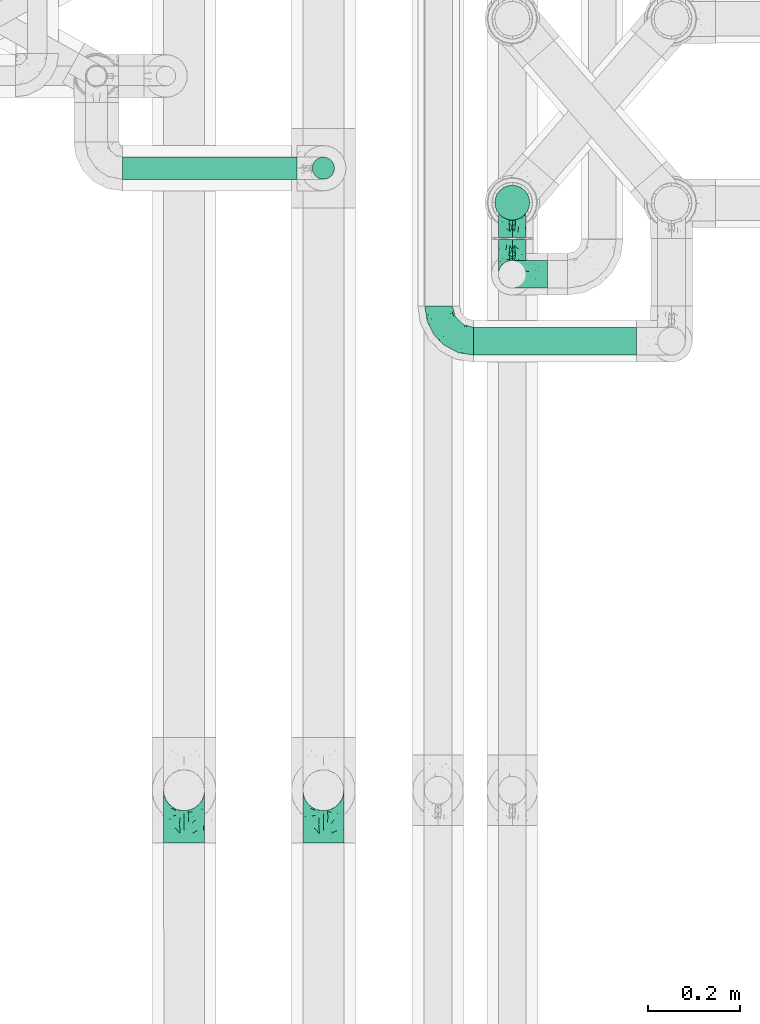
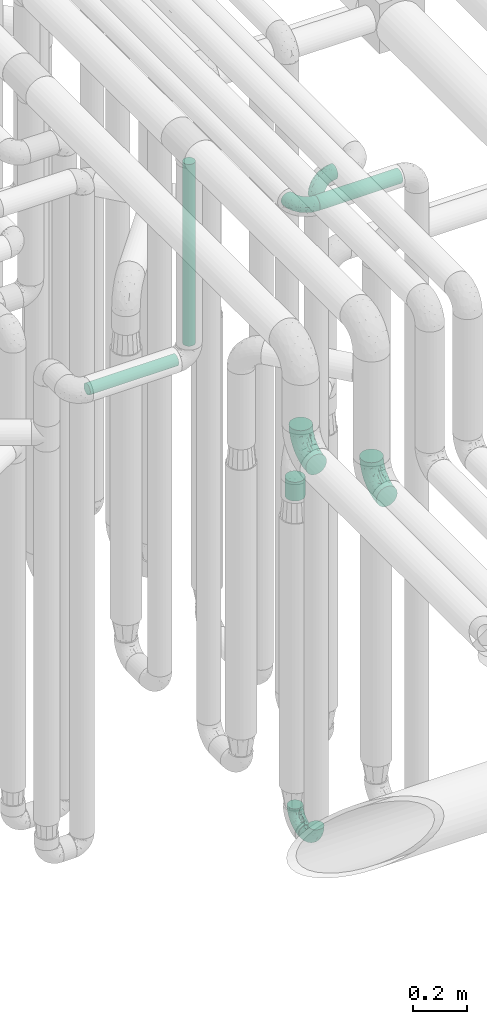
# One storey, part 606 of 827: 6 flow fittings, 4 flow segments.
"""IFC2X3 building model written with IfcOpenShell, lengths in millimetres."""

from ifc_helpers import new_model, entity, si_unit, converted_unit, derived_unit, direction, frame, origin, origin_2d_with_axis, place, context, subcontext, project, spatial, polyline, circle, outline, extrude, faceted_brep, source, transform, mapped, material, type_object, type_shapes, element, save


model = new_model("IFC2X3")

# Units and contexts
model_context = context("Model", 3, precision=0.01, world=origin(), true_north=direction((6.12303176911189e-17, 1.0)))
body_context = subcontext(model_context, "Body", "Model", "MODEL_VIEW")
ifc_project = project(units=[si_unit("LENGTHUNIT", "METRE", prefix="MILLI"), si_unit("AREAUNIT", "SQUARE_METRE"), si_unit("VOLUMEUNIT", "CUBIC_METRE"), converted_unit("PLANEANGLEUNIT", "DEGREE", entity("IfcRatioMeasure", 0.0174532925199433), si_unit("PLANEANGLEUNIT", "RADIAN"), dimensions=[0, 0, 0, 0, 0, 0, 0]), si_unit("MASSUNIT", "GRAM", prefix="KILO"), derived_unit("MASSDENSITYUNIT", [(si_unit("MASSUNIT", "GRAM", prefix="KILO"), 1), (si_unit("LENGTHUNIT", "METRE"), -3)]), derived_unit("MOMENTOFINERTIAUNIT", [(si_unit("LENGTHUNIT", "METRE"), 4)]), si_unit("TIMEUNIT", "SECOND"), si_unit("FREQUENCYUNIT", "HERTZ"), si_unit("THERMODYNAMICTEMPERATUREUNIT", "DEGREE_CELSIUS"), derived_unit("THERMALTRANSMITTANCEUNIT", [(si_unit("MASSUNIT", "GRAM", prefix="KILO"), 1), (si_unit("THERMODYNAMICTEMPERATUREUNIT", "KELVIN"), -1), (si_unit("TIMEUNIT", "SECOND"), -3)]), derived_unit("VOLUMETRICFLOWRATEUNIT", [(si_unit("LENGTHUNIT", "METRE"), 3), (si_unit("TIMEUNIT", "SECOND"), -1)]), derived_unit("MASSFLOWRATEUNIT", [(si_unit("MASSUNIT", "GRAM", prefix="KILO"), 1), (si_unit("TIMEUNIT", "SECOND"), -1)]), derived_unit("ROTATIONALFREQUENCYUNIT", [(si_unit("TIMEUNIT", "SECOND"), -1)]), si_unit("ELECTRICCURRENTUNIT", "AMPERE"), si_unit("ELECTRICVOLTAGEUNIT", "VOLT"), si_unit("POWERUNIT", "WATT"), si_unit("FORCEUNIT", "NEWTON", prefix="KILO"), si_unit("ILLUMINANCEUNIT", "LUX"), si_unit("LUMINOUSFLUXUNIT", "LUMEN"), si_unit("LUMINOUSINTENSITYUNIT", "CANDELA"), derived_unit("USERDEFINED", [(si_unit("MASSUNIT", "GRAM", prefix="KILO"), -1), (si_unit("LENGTHUNIT", "METRE"), -2), (si_unit("TIMEUNIT", "SECOND"), 3), (si_unit("LUMINOUSFLUXUNIT", "LUMEN"), 1)]), derived_unit("LINEARVELOCITYUNIT", [(si_unit("LENGTHUNIT", "METRE"), 1), (si_unit("TIMEUNIT", "SECOND"), -1)]), si_unit("PRESSUREUNIT", "PASCAL"), derived_unit("USERDEFINED", [(si_unit("LENGTHUNIT", "METRE"), -2), (si_unit("MASSUNIT", "GRAM", prefix="KILO"), 1), (si_unit("TIMEUNIT", "SECOND"), -2)]), derived_unit("LINEARFORCEUNIT", [(si_unit("MASSUNIT", "GRAM", prefix="KILO"), 1), (si_unit("LENGTHUNIT", "METRE"), 1), (si_unit("TIMEUNIT", "SECOND"), -2), (si_unit("LENGTHUNIT", "METRE"), -1)]), derived_unit("PLANARFORCEUNIT", [(si_unit("MASSUNIT", "GRAM", prefix="KILO"), 1), (si_unit("LENGTHUNIT", "METRE"), 1), (si_unit("TIMEUNIT", "SECOND"), -2), (si_unit("LENGTHUNIT", "METRE"), -2)])], contexts=[model_context])

# Site, building, storey
site_placement = place(None, origin())
site = spatial("IfcSite", under=ifc_project, at=site_placement, CompositionType="ELEMENT")
building_placement = place(site_placement, origin())
building = spatial("IfcBuilding", under=site, at=building_placement, CompositionType="ELEMENT")
storey_placement = place(building_placement, frame((0.0, 0.0, 28200.0)))
storey = spatial("IfcBuildingStorey", under=building, at=storey_placement, Name="08", CompositionType="ELEMENT", Elevation=28200.0)

# Flow segments
pipe_segment_type = type_object("IfcPipeSegmentType", PredefinedType="NOTDEFINED")
flow_segment_1_placement = place(storey_placement, frame((36546.03, 9749.43, 3368.4)))
element("IfcFlowSegment", 1, at=flow_segment_1_placement, inside=storey, type_object=pipe_segment_type, context=body_context, shape_type="SweptSolid", body=[
    extrude(circle(Radius=30.0, at=origin_2d_with_axis()), frame((0.0, 31.6, 31.6), z_axis=(1.0, 0.0, 0.0), x_axis=(0.0, 1.0, 0.0)), (0.0, 0.0, 1.0), 352.999982000091),
])
flow_segment_2_placement = place(storey_placement, frame((36590.3, 10042.25, 1870.0)))
element("IfcFlowSegment", 2, at=flow_segment_2_placement, inside=storey, type_object=pipe_segment_type, context=body_context, shape_type="SweptSolid", body=[
    extrude(circle(Radius=37.75, at=origin_2d_with_axis()), frame((39.35, 39.35, 0.0)), (0.0, 0.0, 1.0), 84.9999999999937),
])
flow_segment_3_placement = place(storey_placement, frame((35785.05, 10130.61, 2574.4)))
element("IfcFlowSegment", 3, at=flow_segment_3_placement, inside=storey, type_object=pipe_segment_type, context=body_context, shape_type="SweptSolid", body=[
    extrude(circle(Radius=24.0, at=origin_2d_with_axis()), frame((0.0, 25.6, 25.6), z_axis=(1.0, 0.0, 0.0), x_axis=(0.0, -1.0, 0.0)), (0.0, 0.0, 1.0), 377.986139621842),
])
flow_segment_4_placement = place(storey_placement, frame((36194.44, 10130.61, 2657.0)))
element("IfcFlowSegment", 4, at=flow_segment_4_placement, inside=storey, type_object=pipe_segment_type, context=body_context, shape_type="SweptSolid", body=[
    extrude(outline(polyline([(-3.13, -23.79), (3.13, -23.79), (9.18, -22.17), (14.61, -19.04), (19.04, -14.61), (22.17, -9.18), (23.79, -3.13), (23.79, 3.13), (22.17, 9.18), (19.04, 14.61), (14.61, 19.04), (9.18, 22.17), (3.13, 23.79), (-3.13, 23.79), (-9.18, 22.17), (-14.61, 19.04), (-19.04, 14.61), (-22.17, 9.18), (-23.79, 3.13), (-23.79, -3.13), (-22.17, -9.18), (-19.04, -14.61), (-14.61, -19.04), (-9.18, -22.17), (-3.13, -23.79)])), frame((25.6, 25.6, 0.0), z_axis=(0.0, -8.11528883373535e-09, 1.0), x_axis=(-0.130526192219642, 0.991444861373864, 8.04589959840434e-09)), (0.0, 0.0, 1.0), 820.000297304601),
])

# Flow fittings
ifc_material = material()
pipe_fitting_type_1 = type_object("IfcPipeFittingType", Name="ADSK_1", PredefinedType="NOTDEFINED", material=ifc_material)
shared_shape_1 = source(origin(), body_context, "Body", "Brep", [
    faceted_brep([(-76.0, 15.07, -26.11), (-76.0, 7.8, -29.12), (-76.0, 0.0, -30.15), (-76.0, -7.8, -29.12), (-76.0, -15.08, -26.11), (-76.0, -21.32, -21.32), (-76.0, -26.11, -15.08), (-76.0, -29.12, -7.8), (-76.0, -30.15, 0.0), (-76.0, -29.12, 7.8), (-76.0, -26.11, 15.07), (-76.0, -21.32, 21.32), (-76.0, -15.08, 26.11), (-76.0, -7.8, 29.12), (-76.0, 0.0, 30.15), (-76.0, 7.8, 29.12), (-76.0, 15.07, 26.11), (-76.0, 21.32, 21.32), (-76.0, 26.11, 15.07), (-76.0, 29.12, 7.8), (-76.0, 30.15, 0.0), (-76.0, 29.12, -7.8), (-76.0, 26.11, -15.08), (-76.0, 21.32, -21.32), (0.0, 76.0, -30.15), (-7.8, 76.0, -29.12), (-15.07, 76.0, -26.11), (-21.32, 76.0, -21.32), (-26.11, 76.0, -15.08), (-29.12, 76.0, -7.8), (-30.15, 76.0, 0.0), (-29.12, 76.0, 7.8), (-26.11, 76.0, 15.07), (-21.32, 76.0, 21.32), (-15.07, 76.0, 26.11), (-7.8, 76.0, 29.12), (0.0, 76.0, 30.15), (7.8, 76.0, 29.12), (15.08, 76.0, 26.11), (21.32, 76.0, 21.32), (26.11, 76.0, 15.07), (29.12, 76.0, 7.8), (30.15, 76.0, 0.0), (29.12, 76.0, -7.8), (26.11, 76.0, -15.08), (21.32, 76.0, -21.32), (15.08, 76.0, -26.11), (7.8, 76.0, -29.12), (10.79, 31.43, 21.07), (4.32, 31.7, 25.72), (1.65, 15.19, 19.92), (-61.17, -27.8, 0.0), (-51.1, -25.49, 9.84), (-56.14, -10.61, 27.27), (-31.7, -4.32, 25.72), (-39.75, 1.72, 29.41), (-43.2, -24.95, 0.0), (-1.86, 1.86, 0.0), (4.49, 7.65, 5.78), (-7.82, -4.61, 5.83), (-56.21, -22.79, 17.21), (-58.98, -3.38, 29.7), (-53.96, 5.6, 30.07), (-10.86, 10.86, 25.48), (-17.2, -2.6, 20.44), (-49.15, -16.01, 22.7), (-22.18, -14.24, 7.99), (-28.4, -17.42, 0.0), (-13.61, -9.88, 0.0), (-39.0, 23.48, 27.76), (-58.76, 12.54, 28.36), (-41.61, 15.41, 29.48), (16.01, 49.15, 22.7), (-58.55, 25.93, 19.53), (-51.53, 33.5, 13.51), (-64.92, 28.76, 12.4), (-7.48, 23.14, 28.25), (-1.72, 39.75, 29.41), (-12.04, 27.88, 29.88), (-63.91, 18.81, 24.52), (-11.63, 65.16, 28.18), (-4.97, 57.02, 30.05), (9.88, 13.61, 0.0), (-62.5, 31.74, 5.02), (-45.17, 30.98, 21.2), (-21.78, 9.76, 28.58), (10.61, 56.14, 27.27), (-32.09, 54.42, 13.26), (22.79, 56.21, 17.21), (15.38, 31.17, 15.63), (25.49, 51.1, 9.84), (21.84, 36.35, 5.92), (24.95, 43.2, 0.0), (3.38, 58.98, 29.7), (-31.17, -15.38, 15.63), (-39.39, 41.78, 15.45), (-34.56, 41.13, 20.79), (-39.81, -23.25, 5.49), (27.8, 61.17, 0.0), (-31.74, 62.5, 5.02), (-53.07, 36.29, 0.0), (-42.95, 42.95, 7.29), (-36.29, 53.07, 0.0), (-19.83, 58.51, 24.79), (-25.48, 60.2, 19.41), (-14.53, 50.96, 28.57), (-13.31, 37.09, 30.07), (-26.16, 40.06, 26.4), (-32.43, -10.35, 21.9), (17.42, 28.4, 0.0), (14.24, 22.18, 7.99), (-38.67, 9.72, 30.15), (-24.66, 17.36, 30.09), (-37.08, 31.49, 24.99), (-49.27, 22.83, 25.24), (-20.8, 38.81, 28.63), (-27.58, 27.58, 29.2), (-36.07, -20.23, 10.71), (-15.19, -6.16, 14.9), (6.6, 15.4, 14.49), (-2.51, 2.51, 11.35), (-65.16, 11.63, -28.18), (-49.15, -16.01, -22.7), (-57.02, 4.97, -30.05), (-25.93, 58.55, -19.53), (-33.5, 51.53, -13.51), (-28.76, 64.92, -12.4), (-60.2, 25.48, -19.41), (-58.51, 19.83, -24.79), (4.61, 7.82, -5.83), (-7.65, -4.49, -5.78), (-2.51, 2.51, -11.35), (-62.5, 31.74, -5.02), (-50.96, 14.53, -28.57), (-37.09, 13.31, -30.07), (-42.95, 42.95, -7.29), (25.49, 51.1, -9.84), (22.79, 56.21, -17.21), (-40.06, 26.16, -26.4), (3.38, 58.98, -29.7), (-5.6, 53.96, -30.07), (-27.88, 12.04, -29.88), (-9.76, 21.78, -28.58), (-23.14, 7.48, -28.25), (-51.1, -25.49, -9.84), (15.38, 31.17, -15.63), (16.01, 49.15, -22.7), (-23.48, 39.0, -27.76), (-12.54, 58.76, -28.36), (-15.41, 41.61, -29.48), (-56.21, -22.79, -17.21), (-9.72, 38.67, -30.15), (-17.36, 24.66, -30.09), (-22.18, -14.24, -7.99), (-41.13, 34.56, -20.79), (-31.74, 62.5, -5.02), (-58.98, -3.38, -29.7), (-31.17, -15.38, -15.63), (-56.14, -10.61, -27.27), (14.24, 22.18, -7.99), (23.25, 39.81, -5.49), (-31.49, 37.08, -24.99), (-15.19, -6.16, -14.9), (1.65, 15.19, -19.92), (-18.81, 63.91, -24.52), (-32.59, -11.62, -20.84), (-31.7, -4.32, -25.72), (-17.2, -2.6, -20.44), (-39.75, 1.72, -29.41), (-54.42, 32.09, -13.26), (-30.98, 45.17, -21.2), (10.61, 56.14, -27.27), (10.23, 31.31, -21.52), (4.32, 31.7, -25.72), (-41.78, 39.39, -15.45), (-1.72, 39.75, -29.41), (-36.35, -21.84, -5.92), (-22.83, 49.27, -25.24), (-38.81, 20.8, -28.63), (-27.58, 27.58, -29.2), (-10.86, 10.86, -25.48), (20.23, 36.07, -10.71), (6.6, 15.4, -14.49)], [[[0, 1, 2, 3, 4, 5, 6, 7, 8, 9, 10, 11, 12, 13, 14, 15, 16, 17, 18, 19, 20, 21, 22, 23]], [[24, 25, 26, 27, 28, 29, 30, 31, 32, 33, 34, 35, 36, 37, 38, 39, 40, 41, 42, 43, 44, 45, 46, 47]], [[48, 49, 50]], [[51, 52, 9]], [[53, 54, 55]], [[9, 52, 10]], [[56, 52, 51]], [[57, 58, 59]], [[11, 10, 60]], [[14, 61, 62]], [[63, 54, 64]], [[65, 12, 11]], [[65, 53, 12]], [[66, 67, 68]], [[69, 70, 71]], [[72, 39, 38]], [[73, 74, 75]], [[15, 70, 16]], [[76, 77, 78]], [[16, 79, 17]], [[13, 61, 14]], [[35, 80, 81]], [[14, 62, 15]], [[17, 73, 18]], [[57, 82, 58]], [[20, 19, 83]], [[75, 19, 18]], [[70, 15, 62]], [[73, 84, 74]], [[78, 85, 76]], [[38, 86, 72]], [[32, 31, 87]], [[88, 89, 90]], [[91, 92, 90]], [[72, 86, 49]], [[36, 93, 37]], [[75, 83, 19]], [[36, 35, 81]], [[60, 94, 65]], [[40, 90, 41]], [[95, 96, 87]], [[88, 90, 40]], [[66, 97, 67]], [[90, 98, 41]], [[40, 39, 88]], [[99, 31, 30]], [[20, 83, 100]], [[101, 102, 100]], [[52, 60, 10]], [[102, 99, 30]], [[96, 103, 104]], [[83, 101, 100]], [[12, 53, 13]], [[104, 103, 33]], [[105, 106, 81]], [[107, 105, 103]], [[64, 54, 108]], [[80, 103, 105]], [[80, 35, 34]], [[34, 33, 103]], [[86, 38, 37]], [[109, 110, 82]], [[71, 111, 112]], [[69, 107, 113]], [[79, 73, 17]], [[114, 113, 84]], [[33, 32, 104]], [[115, 107, 116]], [[105, 115, 106]], [[93, 81, 77]], [[54, 53, 65]], [[61, 53, 55]], [[108, 94, 64]], [[54, 63, 85]], [[93, 86, 37]], [[77, 76, 49]], [[77, 49, 86]], [[49, 63, 50]], [[60, 52, 117]], [[65, 11, 60]], [[39, 72, 88]], [[89, 88, 72]], [[71, 70, 62]], [[79, 70, 114]], [[103, 96, 107]], [[69, 113, 114]], [[112, 106, 116]], [[77, 81, 106]], [[112, 116, 71]], [[112, 55, 85]], [[64, 50, 63]], [[57, 59, 68]], [[32, 87, 104]], [[96, 104, 87]], [[94, 118, 64]], [[50, 119, 89]], [[50, 64, 118]], [[50, 89, 48]], [[81, 93, 36]], [[86, 93, 77]], [[53, 61, 13]], [[62, 61, 55]], [[71, 62, 111]], [[69, 71, 116]], [[95, 101, 74]], [[99, 101, 87]], [[118, 66, 59]], [[117, 97, 66]], [[117, 66, 94]], [[91, 89, 110]], [[91, 110, 109]], [[110, 89, 119]], [[9, 8, 51]], [[98, 90, 92]], [[98, 42, 41]], [[101, 83, 74]], [[101, 99, 102]], [[87, 31, 99]], [[62, 55, 111]], [[55, 112, 111]], [[107, 69, 116]], [[70, 69, 114]], [[107, 96, 113]], [[84, 113, 96]], [[84, 96, 95]], [[114, 84, 73]], [[70, 79, 16]], [[73, 79, 114]], [[54, 85, 55]], [[76, 85, 63]], [[49, 76, 63]], [[77, 106, 78]], [[106, 112, 78]], [[85, 78, 112]], [[73, 75, 18]], [[83, 75, 74]], [[103, 80, 34]], [[81, 80, 105]], [[101, 95, 87]], [[84, 95, 74]], [[106, 115, 116]], [[105, 107, 115]], [[120, 59, 58]], [[82, 110, 58]], [[119, 58, 110]], [[118, 59, 120]], [[66, 68, 59]], [[54, 65, 108]], [[94, 108, 65]], [[66, 118, 94]], [[50, 118, 120]], [[50, 120, 119]], [[119, 120, 58]], [[89, 72, 48]], [[49, 48, 72]], [[60, 117, 94]], [[117, 52, 97]], [[52, 56, 97]], [[67, 97, 56]], [[92, 91, 109]], [[89, 91, 90]], [[121, 1, 0]], [[122, 5, 4]], [[2, 1, 123]], [[124, 125, 126]], [[127, 128, 23]], [[129, 130, 131]], [[100, 132, 20]], [[133, 134, 123]], [[135, 100, 102]], [[136, 137, 44]], [[133, 128, 138]], [[24, 139, 140]], [[141, 142, 143]], [[121, 128, 133]], [[6, 144, 7]], [[137, 145, 146]], [[144, 51, 7]], [[147, 148, 149]], [[144, 6, 150]], [[149, 151, 152]], [[153, 68, 67]], [[154, 128, 127]], [[30, 155, 102]], [[43, 42, 98]], [[156, 3, 2]], [[157, 144, 150]], [[158, 4, 3]], [[24, 140, 25]], [[155, 135, 102]], [[159, 160, 109]], [[30, 29, 155]], [[147, 138, 161]], [[27, 124, 28]], [[57, 129, 82]], [[162, 163, 131]], [[27, 26, 164]], [[148, 26, 25]], [[165, 166, 167]], [[24, 47, 139]], [[143, 168, 141]], [[22, 21, 169]], [[125, 124, 170]], [[148, 25, 140]], [[46, 146, 171]], [[158, 122, 4]], [[0, 23, 128]], [[1, 121, 123]], [[109, 82, 159]], [[45, 44, 137]], [[146, 46, 45]], [[136, 43, 98]], [[132, 21, 20]], [[136, 98, 92]], [[172, 173, 146]], [[46, 171, 47]], [[43, 136, 44]], [[174, 154, 169]], [[171, 173, 175]], [[6, 5, 150]], [[126, 29, 28]], [[176, 56, 144]], [[122, 158, 166]], [[164, 124, 27]], [[177, 161, 170]], [[23, 22, 127]], [[178, 138, 179]], [[133, 178, 134]], [[156, 123, 168]], [[156, 158, 3]], [[168, 143, 166]], [[168, 166, 158]], [[166, 180, 167]], [[173, 171, 146]], [[139, 171, 175]], [[172, 145, 163]], [[173, 180, 142]], [[5, 122, 150]], [[157, 150, 122]], [[137, 136, 181]], [[146, 45, 137]], [[149, 148, 140]], [[164, 148, 177]], [[128, 154, 138]], [[147, 161, 177]], [[152, 134, 179]], [[168, 123, 134]], [[152, 179, 149]], [[152, 175, 142]], [[57, 130, 129]], [[157, 165, 167]], [[22, 169, 127]], [[154, 127, 169]], [[163, 167, 180]], [[162, 157, 167]], [[173, 163, 180]], [[182, 163, 145]], [[123, 156, 2]], [[158, 156, 168]], [[171, 139, 47]], [[140, 139, 175]], [[149, 140, 151]], [[147, 149, 179]], [[174, 135, 125]], [[132, 135, 169]], [[176, 157, 153]], [[176, 153, 67]], [[153, 157, 162]], [[182, 159, 129]], [[181, 160, 159]], [[181, 159, 145]], [[51, 144, 56]], [[51, 8, 7]], [[135, 132, 100]], [[169, 21, 132]], [[126, 155, 29]], [[135, 155, 125]], [[140, 175, 151]], [[175, 152, 151]], [[138, 147, 179]], [[148, 147, 177]], [[138, 154, 161]], [[170, 161, 154]], [[170, 154, 174]], [[177, 170, 124]], [[148, 164, 26]], [[124, 164, 177]], [[173, 142, 175]], [[143, 142, 180]], [[166, 143, 180]], [[168, 134, 141]], [[134, 152, 141]], [[142, 141, 152]], [[124, 126, 28]], [[155, 126, 125]], [[128, 121, 0]], [[123, 121, 133]], [[135, 174, 169]], [[170, 174, 125]], [[134, 178, 179]], [[133, 138, 178]], [[130, 153, 162]], [[68, 153, 130]], [[57, 68, 130]], [[182, 129, 131]], [[159, 82, 129]], [[157, 122, 165]], [[166, 165, 122]], [[163, 162, 167]], [[162, 131, 130]], [[145, 172, 146]], [[163, 173, 172]], [[159, 182, 145]], [[131, 163, 182]], [[56, 176, 67]], [[157, 176, 144]], [[137, 181, 145]], [[181, 136, 160]], [[136, 92, 160]], [[109, 160, 92]]]),
])
type_shapes(pipe_fitting_type_1, [shared_shape_1])
for number, where, z_axis, x_axis, name in (
    (5, (36629.64, 10081.59, 400.0), (1.0, 0.0, 0.0), (0.0, 1.0, 0.0), "ADSK_1"),
    (6, (36629.64, 9926.17, 400.0), (-1.0, 0.0, 0.0), (0.0, -1.0, 0.0), "ADSK_1"),
    (7, (36629.64, 9926.17, 3400.0), (0.0, 1.0, 0.0), (0.0, 0.0, 1.0), "ADSK_1"),
    (8, (36470.03, 9781.02, 3400.0), (0.0, 0.0, 1.0), (0.0, -1.0, 0.0), "ADSK_1"),
):
    element("IfcFlowFitting", number, at=place(storey_placement, frame(where, z_axis=z_axis, x_axis=x_axis)), inside=storey, type_object=pipe_fitting_type_1, material=ifc_material, Name=name, ObjectType="ADSK_1", context=body_context, shape_type="MappedRepresentation", body=[
        mapped(shared_shape_1, transform((0.0, 0.0, 0.0), scale=1.0)),
    ])
pipe_fitting_type_2 = type_object("IfcPipeFittingType", Name="ADSK_1", PredefinedType="NOTDEFINED", material=ifc_material)
shared_shape_2 = source(origin(), body_context, "Body", "Brep", [
    faceted_brep([(-114.0, 22.22, -38.49), (-114.0, 11.5, -42.94), (-114.0, 0.0, -44.45), (-114.0, -11.5, -42.94), (-114.0, -22.23, -38.49), (-114.0, -31.43, -31.43), (-114.0, -38.49, -22.23), (-114.0, -42.94, -11.5), (-114.0, -44.45, 0.0), (-114.0, -42.94, 11.5), (-114.0, -38.49, 22.22), (-114.0, -31.43, 31.43), (-114.0, -22.23, 38.49), (-114.0, -11.5, 42.94), (-114.0, 0.0, 44.45), (-114.0, 11.5, 42.94), (-114.0, 22.22, 38.49), (-114.0, 31.43, 31.43), (-114.0, 38.49, 22.22), (-114.0, 42.94, 11.5), (-114.0, 44.45, 0.0), (-114.0, 42.94, -11.5), (-114.0, 38.49, -22.23), (-114.0, 31.43, -31.43), (0.0, 114.0, -44.45), (-11.5, 114.0, -42.94), (-22.22, 114.0, -38.49), (-31.43, 114.0, -31.43), (-38.49, 114.0, -22.23), (-42.94, 114.0, -11.5), (-44.45, 114.0, 0.0), (-42.94, 114.0, 11.5), (-38.49, 114.0, 22.22), (-31.43, 114.0, 31.43), (-22.22, 114.0, 38.49), (-11.5, 114.0, 42.94), (0.0, 114.0, 44.45), (11.5, 114.0, 42.94), (22.23, 114.0, 38.49), (31.43, 114.0, 31.43), (38.49, 114.0, 22.22), (42.94, 114.0, 11.5), (44.45, 114.0, 0.0), (42.94, 114.0, -11.5), (38.49, 114.0, -22.23), (31.43, 114.0, -31.43), (22.23, 114.0, -38.49), (11.5, 114.0, -42.94), (-24.5, -15.82, 8.24), (-7.18, -2.06, 7.97), (-13.53, -4.79, 15.72), (-92.03, -41.56, 0.0), (-77.08, -37.56, 14.57), (23.74, 74.96, 33.55), (-72.99, -39.05, 0.0), (-84.56, -15.6, 40.23), (-47.88, -6.37, 37.83), (-59.8, 2.77, 43.37), (-84.46, -33.54, 25.41), (16.69, 49.28, 31.02), (6.37, 47.88, 37.83), (3.35, 25.47, 29.77), (-47.43, 81.55, 19.51), (-74.96, -23.74, 33.55), (-46.77, -27.89, 11.23), (-53.88, -31.14, 0.0), (-87.05, 38.52, 28.81), (-63.44, 55.78, 24.79), (-93.24, 43.37, 18.58), (-16.67, 16.67, 37.64), (-25.47, -3.35, 29.77), (-17.2, 97.7, 41.53), (-7.42, 85.54, 44.3), (-67.09, 46.29, 31.23), (-18.08, 42.1, 44.06), (-32.93, 14.9, 42.17), (-11.54, 34.94, 41.69), (-95.7, 27.79, 36.14), (-88.55, -4.92, 43.79), (-2.77, 59.8, 43.37), (-87.65, 48.44, 9.87), (-81.01, 8.37, 44.32), (-37.63, 90.26, 28.6), (-51.29, 61.56, 30.59), (-29.32, 87.72, 36.52), (23.49, 49.5, 23.28), (8.19, 20.11, 19.18), (-70.06, 58.9, 9.01), (-87.38, 49.74, 0.0), (-88.15, 18.57, 41.8), (-7.96, 6.22, 24.33), (33.54, 84.46, 25.41), (37.56, 77.08, 14.57), (-58.37, 34.98, 40.92), (-62.38, 23.02, 43.45), (24.15, 39.93, 12.16), (31.14, 53.88, 0.0), (-58.13, 14.61, 44.45), (-37.17, 26.09, 44.37), (4.92, 88.55, 43.79), (-34.77, -23.22, 0.0), (-49.5, -23.49, 23.28), (41.56, 92.03, 0.0), (-57.83, 66.03, 19.12), (-71.84, 54.46, 17.06), (-46.46, 94.23, 8.51), (-49.74, 87.38, 0.0), (-38.96, 59.98, 38.88), (-55.29, 46.95, 36.83), (-64.82, 64.82, 0.0), (-55.88, 73.75, 10.01), (15.6, 84.56, 40.23), (-21.6, 76.38, 42.11), (-49.04, -15.53, 31.95), (-19.97, 55.59, 44.33), (-73.61, 33.95, 37.2), (-31.05, 58.14, 42.19), (-41.3, 41.3, 43.02), (-27.36, -11.22, 22.61), (9.28, 15.84, 8.73), (23.22, 34.77, 0.0), (39.05, 72.99, 0.0), (-1.96, 1.96, 0.0), (10.63, 18.37, 0.0), (-18.37, -10.63, 0.0), (-97.7, 17.2, -41.53), (9.28, 15.84, -8.73), (-13.53, -4.79, -15.72), (8.19, 20.11, -19.18), (-85.54, 7.42, -44.3), (-8.37, 81.01, -44.32), (-90.26, 37.63, -28.6), (-87.72, 29.32, -36.52), (-27.79, 95.7, -36.14), (-38.52, 87.05, -28.81), (-94.23, 46.46, -8.51), (-84.56, -15.6, -40.23), (-73.75, 55.88, -10.01), (-10.19, -4.86, -7.51), (-76.38, 21.6, -42.11), (-59.98, 38.96, -38.88), (-49.28, -16.69, -31.02), (-47.88, -6.37, -37.83), (-25.47, -3.35, -29.77), (-34.98, 58.37, -40.92), (-46.95, 55.29, -36.83), (-77.08, -37.56, -14.57), (-18.57, 88.15, -41.8), (-23.02, 62.38, -43.45), (-55.78, 63.44, -24.79), (-43.37, 93.24, -18.58), (-84.46, -33.54, -25.41), (-33.95, 73.61, -37.2), (-46.29, 67.09, -31.23), (-74.96, -23.74, -33.55), (-48.44, 87.65, -9.87), (-45.44, -27.06, -11.87), (-88.55, -4.92, -43.79), (-49.5, -23.49, -23.28), (-14.61, 58.13, -44.45), (-26.09, 37.17, -44.37), (15.6, 84.56, -40.23), (6.37, 47.88, -37.83), (-2.77, 59.8, -43.37), (-81.55, 47.43, -19.51), (33.54, 84.46, -25.41), (23.49, 49.5, -23.28), (23.74, 74.96, -33.55), (-42.1, 18.08, -44.06), (-14.9, 32.93, -42.17), (-34.94, 11.54, -41.69), (-61.56, 51.29, -30.59), (-27.36, -11.22, -22.61), (37.56, 77.08, -14.57), (4.92, 88.55, -43.79), (-59.8, 2.77, -43.37), (-66.03, 57.83, -19.12), (-54.46, 71.84, -17.06), (-55.59, 19.97, -44.33), (-58.9, 70.06, -9.01), (24.15, 39.93, -12.16), (15.53, 49.04, -31.95), (-58.14, 31.05, -42.19), (-41.3, 41.3, -43.02), (-16.67, 16.67, -37.64), (3.35, 25.47, -29.77), (-7.96, 6.22, -24.33), (-26.36, -16.33, -11.05)], [[[0, 1, 2, 3, 4, 5, 6, 7, 8, 9, 10, 11, 12, 13, 14, 15, 16, 17, 18, 19, 20, 21, 22, 23]], [[24, 25, 26, 27, 28, 29, 30, 31, 32, 33, 34, 35, 36, 37, 38, 39, 40, 41, 42, 43, 44, 45, 46, 47]], [[48, 49, 50]], [[51, 52, 9]], [[53, 39, 38]], [[9, 52, 10]], [[54, 52, 51]], [[55, 56, 57]], [[11, 10, 58]], [[59, 60, 61]], [[32, 31, 62]], [[63, 12, 11]], [[63, 55, 12]], [[64, 52, 65]], [[66, 67, 68]], [[69, 56, 70]], [[35, 71, 72]], [[67, 66, 73]], [[74, 75, 76]], [[16, 77, 17]], [[13, 78, 14]], [[76, 79, 74]], [[68, 80, 19]], [[18, 17, 66]], [[14, 78, 81]], [[20, 19, 80]], [[82, 83, 84]], [[85, 61, 86]], [[87, 88, 80]], [[18, 68, 19]], [[15, 89, 16]], [[14, 81, 15]], [[70, 90, 61]], [[17, 77, 66]], [[91, 85, 92]], [[93, 89, 94]], [[95, 96, 92]], [[84, 71, 34]], [[94, 97, 98]], [[37, 36, 99]], [[40, 39, 91]], [[40, 92, 41]], [[65, 100, 64]], [[91, 92, 40]], [[58, 101, 63]], [[92, 102, 41]], [[92, 85, 95]], [[67, 103, 104]], [[34, 33, 84]], [[105, 62, 31]], [[52, 58, 10]], [[106, 105, 30]], [[93, 107, 108]], [[106, 109, 110]], [[53, 111, 60]], [[84, 112, 71]], [[84, 107, 112]], [[33, 82, 84]], [[12, 55, 13]], [[113, 56, 63]], [[111, 38, 37]], [[34, 71, 35]], [[36, 35, 72]], [[112, 114, 72]], [[110, 105, 106]], [[111, 53, 38]], [[115, 108, 73]], [[89, 15, 81]], [[104, 87, 80]], [[110, 87, 103]], [[33, 32, 82]], [[116, 107, 117]], [[112, 116, 114]], [[99, 72, 79]], [[56, 55, 63]], [[78, 55, 57]], [[101, 118, 113]], [[56, 69, 75]], [[99, 111, 37]], [[79, 76, 60]], [[79, 60, 111]], [[60, 69, 61]], [[101, 58, 52]], [[63, 11, 58]], [[39, 53, 91]], [[85, 91, 53]], [[94, 89, 81]], [[77, 89, 115]], [[84, 83, 107]], [[93, 108, 115]], [[98, 114, 117]], [[79, 72, 114]], [[98, 117, 94]], [[98, 57, 75]], [[32, 62, 82]], [[83, 82, 62]], [[70, 113, 118]], [[61, 85, 59]], [[48, 64, 100]], [[95, 119, 120]], [[69, 70, 61]], [[70, 118, 90]], [[72, 99, 36]], [[111, 99, 79]], [[55, 78, 13]], [[81, 78, 57]], [[94, 81, 97]], [[93, 94, 117]], [[66, 68, 18]], [[80, 68, 104]], [[103, 87, 104]], [[80, 88, 20]], [[50, 49, 119]], [[95, 85, 86]], [[119, 95, 86]], [[121, 92, 96]], [[50, 119, 86]], [[119, 122, 123, 120]], [[110, 109, 87]], [[88, 87, 109]], [[62, 105, 110]], [[30, 105, 31]], [[81, 57, 97]], [[57, 98, 97]], [[107, 93, 117]], [[89, 93, 115]], [[107, 83, 108]], [[73, 108, 83]], [[67, 73, 83]], [[115, 73, 66]], [[103, 83, 62]], [[67, 104, 68]], [[83, 103, 67]], [[110, 103, 62]], [[89, 77, 16]], [[66, 77, 115]], [[56, 75, 57]], [[76, 75, 69]], [[60, 76, 69]], [[79, 114, 74]], [[114, 98, 74]], [[75, 74, 98]], [[9, 8, 51]], [[102, 92, 121]], [[102, 42, 41]], [[72, 71, 112]], [[52, 54, 65]], [[64, 48, 118]], [[101, 52, 64]], [[124, 122, 49]], [[118, 48, 50]], [[49, 48, 124]], [[119, 49, 122]], [[48, 100, 124]], [[114, 116, 117]], [[112, 107, 116]], [[101, 113, 63]], [[70, 56, 113]], [[64, 118, 101]], [[90, 50, 86]], [[50, 90, 118]], [[61, 90, 86]], [[85, 53, 59]], [[60, 59, 53]], [[95, 120, 96]], [[125, 1, 0]], [[126, 127, 128]], [[2, 1, 129]], [[24, 130, 25]], [[131, 132, 23]], [[27, 133, 134]], [[88, 135, 20]], [[136, 4, 3]], [[88, 109, 137]], [[138, 122, 124]], [[139, 132, 140]], [[141, 142, 143]], [[144, 140, 145]], [[125, 132, 139]], [[6, 146, 7]], [[144, 147, 148]], [[146, 51, 7]], [[134, 149, 150]], [[146, 6, 151]], [[152, 145, 153]], [[154, 4, 136]], [[154, 136, 142]], [[150, 155, 29]], [[43, 42, 102]], [[65, 146, 156]], [[0, 23, 132]], [[157, 3, 2]], [[146, 151, 158]], [[148, 159, 160]], [[161, 162, 163]], [[135, 164, 21]], [[165, 166, 167]], [[168, 169, 170]], [[147, 25, 130]], [[171, 132, 131]], [[155, 30, 29]], [[172, 141, 143]], [[134, 28, 27]], [[149, 134, 153]], [[173, 165, 44]], [[26, 25, 147]], [[22, 21, 164]], [[24, 174, 130]], [[133, 27, 26]], [[170, 175, 168]], [[24, 47, 174]], [[45, 167, 46]], [[28, 150, 29]], [[1, 125, 129]], [[156, 100, 65]], [[165, 45, 44]], [[161, 46, 167]], [[173, 44, 43]], [[6, 5, 151]], [[173, 102, 121]], [[137, 135, 88]], [[46, 161, 47]], [[102, 173, 43]], [[149, 176, 177]], [[172, 158, 141]], [[139, 178, 129]], [[154, 5, 4]], [[156, 146, 158]], [[106, 155, 179]], [[173, 96, 180]], [[181, 162, 167]], [[177, 179, 155]], [[137, 179, 176]], [[23, 22, 131]], [[182, 140, 183]], [[139, 182, 178]], [[157, 129, 175]], [[157, 136, 3]], [[175, 170, 142]], [[175, 142, 136]], [[142, 184, 143]], [[162, 161, 167]], [[174, 161, 163]], [[181, 166, 185]], [[162, 184, 169]], [[5, 154, 151]], [[158, 151, 154]], [[166, 165, 173]], [[167, 45, 165]], [[148, 147, 130]], [[133, 147, 152]], [[132, 171, 140]], [[144, 145, 152]], [[160, 178, 183]], [[175, 129, 178]], [[160, 183, 148]], [[160, 163, 169]], [[22, 164, 131]], [[171, 131, 164]], [[162, 185, 184]], [[186, 127, 172]], [[185, 128, 186]], [[156, 187, 100]], [[185, 166, 128]], [[143, 184, 185]], [[129, 157, 2]], [[136, 157, 175]], [[161, 174, 47]], [[130, 174, 163]], [[148, 130, 159]], [[144, 148, 183]], [[134, 150, 28]], [[155, 150, 177]], [[176, 179, 177]], [[155, 106, 30]], [[166, 180, 128]], [[128, 180, 126]], [[173, 180, 166]], [[126, 120, 123, 122]], [[120, 126, 180]], [[122, 138, 126]], [[137, 109, 179]], [[106, 179, 109]], [[164, 135, 137]], [[20, 135, 21]], [[130, 163, 159]], [[163, 160, 159]], [[140, 144, 183]], [[147, 144, 152]], [[140, 171, 145]], [[153, 145, 171]], [[149, 153, 171]], [[152, 153, 134]], [[176, 171, 164]], [[149, 177, 150]], [[171, 176, 149]], [[137, 176, 164]], [[147, 133, 26]], [[134, 133, 152]], [[162, 169, 163]], [[170, 169, 184]], [[142, 170, 184]], [[175, 178, 168]], [[178, 160, 168]], [[169, 168, 160]], [[51, 146, 54]], [[51, 8, 7]], [[132, 125, 0]], [[129, 125, 139]], [[156, 158, 172]], [[65, 54, 146]], [[178, 182, 183]], [[139, 140, 182]], [[158, 154, 141]], [[142, 141, 154]], [[186, 172, 143]], [[172, 127, 187]], [[185, 186, 143]], [[127, 186, 128]], [[187, 127, 138]], [[124, 100, 187]], [[126, 138, 127]], [[187, 138, 124]], [[172, 187, 156]], [[166, 181, 167]], [[185, 162, 181]], [[96, 173, 121]], [[96, 120, 180]]]),
])
type_shapes(pipe_fitting_type_2, [shared_shape_2])
for number, where, z_axis, x_axis, name in (
    (9, (35918.07, 8807.39, 3100.0), (-0.999999671555908, -0.000810486321272664, 0.0), (0.0, 0.0, -1.0), "ADSK_1"),
    (10, (36220.03, 8807.39, 2850.0), (1.0, 0.0, 0.0), (0.0, 1.0, 0.0), "ADSK_1"),
):
    element("IfcFlowFitting", number, at=place(storey_placement, frame(where, z_axis=z_axis, x_axis=x_axis)), inside=storey, type_object=pipe_fitting_type_2, material=ifc_material, Name=name, ObjectType="ADSK_1", context=body_context, shape_type="MappedRepresentation", body=[
        mapped(shared_shape_2, transform((0.0, 0.0, 0.0), scale=1.0)),
    ])

save(model, "model.ifc")
